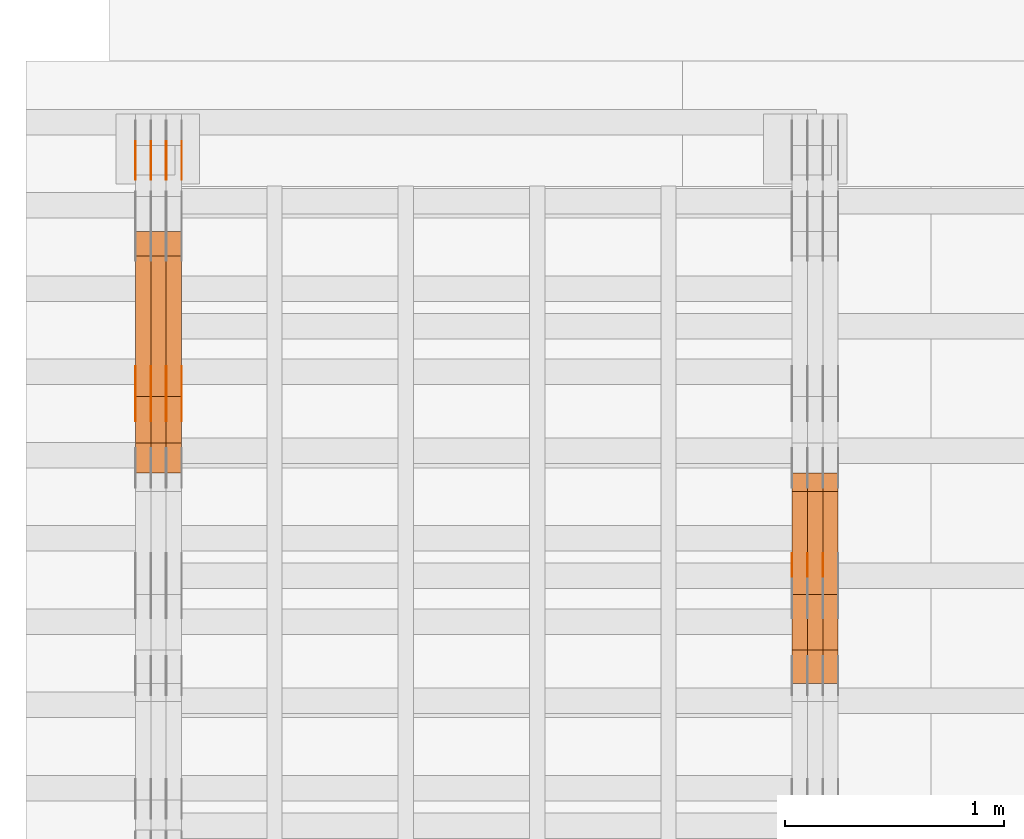
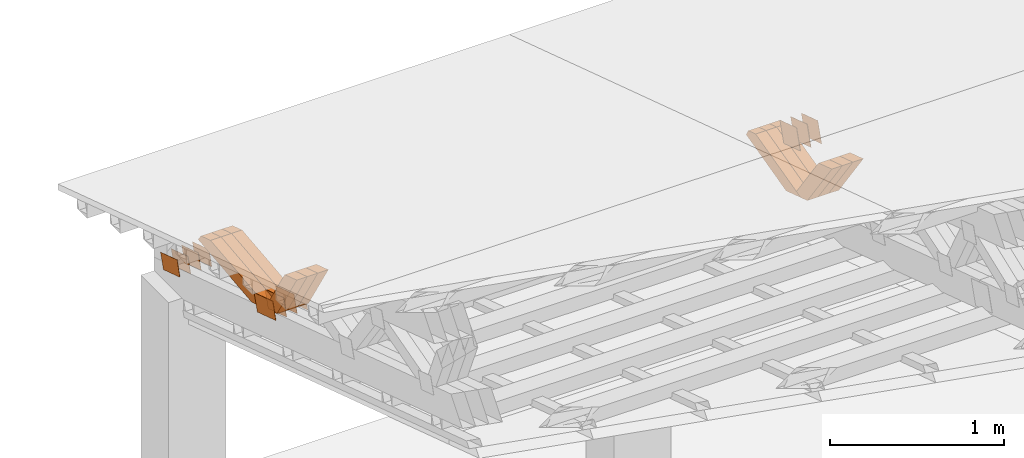
# One storey, part 184 of 385: 28 proxies.
"""IFC2X3 building model written with IfcOpenShell, lengths in millimetres."""

from ifc_helpers import new_model, entity, si_unit, converted_unit, derived_unit, direction, frame, origin, place, context, subcontext, project, spatial, polyline, outline, extrude, source, transform, mapped, material, type_object, type_shapes, element, save


model = new_model("IFC2X3")

# Units and contexts
model_context = context("Model", 3, precision=0.01, world=origin(), true_north=direction((6.12303176911189e-17, 1.0)))
body_context = subcontext(model_context, "Body", "Model", "MODEL_VIEW")
ifc_project = project(units=[si_unit("LENGTHUNIT", "METRE", prefix="MILLI"), si_unit("AREAUNIT", "SQUARE_METRE"), si_unit("VOLUMEUNIT", "CUBIC_METRE"), converted_unit("PLANEANGLEUNIT", "DEGREE", entity("IfcRatioMeasure", 0.0174532925199433), si_unit("PLANEANGLEUNIT", "RADIAN"), dimensions=[0, 0, 0, 0, 0, 0, 0]), si_unit("MASSUNIT", "GRAM", prefix="KILO"), derived_unit("MASSDENSITYUNIT", [(si_unit("MASSUNIT", "GRAM", prefix="KILO"), 1), (si_unit("LENGTHUNIT", "METRE"), -3)]), si_unit("TIMEUNIT", "SECOND"), si_unit("FREQUENCYUNIT", "HERTZ"), si_unit("THERMODYNAMICTEMPERATUREUNIT", "DEGREE_CELSIUS"), derived_unit("THERMALTRANSMITTANCEUNIT", [(si_unit("MASSUNIT", "GRAM", prefix="KILO"), 1), (si_unit("THERMODYNAMICTEMPERATUREUNIT", "KELVIN"), -1), (si_unit("TIMEUNIT", "SECOND"), -3)]), derived_unit("VOLUMETRICFLOWRATEUNIT", [(si_unit("LENGTHUNIT", "METRE"), 3), (si_unit("TIMEUNIT", "SECOND"), -1)]), si_unit("ELECTRICCURRENTUNIT", "AMPERE"), si_unit("ELECTRICVOLTAGEUNIT", "VOLT"), si_unit("POWERUNIT", "WATT"), si_unit("FORCEUNIT", "NEWTON", prefix="KILO"), si_unit("ILLUMINANCEUNIT", "LUX"), si_unit("LUMINOUSFLUXUNIT", "LUMEN"), si_unit("LUMINOUSINTENSITYUNIT", "CANDELA"), derived_unit("USERDEFINED", [(si_unit("MASSUNIT", "GRAM", prefix="KILO"), -1), (si_unit("LENGTHUNIT", "METRE"), -2), (si_unit("TIMEUNIT", "SECOND"), 3), (si_unit("LUMINOUSFLUXUNIT", "LUMEN"), 1)]), derived_unit("LINEARVELOCITYUNIT", [(si_unit("LENGTHUNIT", "METRE"), 1), (si_unit("TIMEUNIT", "SECOND"), -1)]), si_unit("PRESSUREUNIT", "PASCAL"), derived_unit("USERDEFINED", [(si_unit("LENGTHUNIT", "METRE"), -2), (si_unit("MASSUNIT", "GRAM", prefix="KILO"), 1), (si_unit("TIMEUNIT", "SECOND"), -2)])], contexts=[model_context])

# Site, building, storey
site_placement = place(None, origin())
site = spatial("IfcSite", under=ifc_project, at=site_placement, CompositionType="ELEMENT")
building_placement = place(site_placement, origin())
building = spatial("IfcBuilding", under=site, at=building_placement, CompositionType="ELEMENT")
storey_placement = place(building_placement, origin())
storey = spatial("IfcBuildingStorey", under=building, at=storey_placement, Name="Default", CompositionType="ELEMENT", Elevation=0.0)

# Proxies
ifc_material_1 = material(Name="IfcSurfaceStyle #54198")
building_element_proxy_type_1 = type_object("IfcBuildingElementProxyType", PredefinedType="NOTDEFINED", material=ifc_material_1)
shared_shape_1 = source(origin(), body_context, "Body", "SweptSolid", [
    extrude(outline(polyline([(-100.000009625089, -72.0000630699202), (100.000090167682, -72.0000630699202), (100.000009625089, 72.0000630699202), (-100.000090167682, 72.0000630699202), (-100.000009625089, -72.0000630699202)])), frame((100.000090167682, 72.0000630699202, 0.0), z_axis=(0.0, 0.0, 1.0), x_axis=(-1.0, 0.0, 0.0)), (0.0, 0.0, 1.0), 1.3),
])
type_shapes(building_element_proxy_type_1, [shared_shape_1])
proxy_1_placement = place(building_placement, frame((3316.29999999999, 24447.7695802369, 1088.58717039832), z_axis=(-1.0, 0.0, 0.0), x_axis=(0.0, -0.951056516295154, 0.309016994374948)))
element("IfcBuildingElementProxy", 1, at=proxy_1_placement, inside=storey, type_object=building_element_proxy_type_1, material=ifc_material_1, context=body_context, shape_type="MappedRepresentation", body=[
    mapped(shared_shape_1, transform((0.0, 0.0, 0.0), scale=1.0)),
])
ifc_material_2 = material(Name="IfcSurfaceStyle #54141")
building_element_proxy_type_2 = type_object("IfcBuildingElementProxyType", PredefinedType="NOTDEFINED", material=ifc_material_2)
shared_shape_2 = source(origin(), body_context, "Body", "SweptSolid", [
    extrude(outline(polyline([(-100.000009625089, -72.0000630699202), (100.000090167682, -72.0000630699202), (100.000009625089, 72.0000630699202), (-100.000090167682, 72.0000630699202), (-100.000009625089, -72.0000630699202)])), frame((100.000090167682, 72.0000630699202, 0.0), z_axis=(0.0, 0.0, 1.0), x_axis=(-1.0, 0.0, 0.0)), (0.0, 0.0, 1.0), 1.29999999999998),
])
type_shapes(building_element_proxy_type_2, [shared_shape_2])
proxy_2_placement = place(building_placement, frame((3245.0, 24447.7695802369, 1088.58717039832), z_axis=(-1.0, 0.0, 0.0), x_axis=(0.0, -0.951056516295154, 0.309016994374948)))
element("IfcBuildingElementProxy", 2, at=proxy_2_placement, inside=storey, type_object=building_element_proxy_type_2, material=ifc_material_2, context=body_context, shape_type="MappedRepresentation", body=[
    mapped(shared_shape_2, transform((0.0, 0.0, 0.0), scale=1.0)),
])
ifc_material_3 = material(Name="IfcSurfaceStyle #54084")
building_element_proxy_type_3 = type_object("IfcBuildingElementProxyType", PredefinedType="NOTDEFINED", material=ifc_material_3)
shared_shape_3 = source(origin(), body_context, "Body", "SweptSolid", [
    extrude(outline(polyline([(-100.000009625089, -72.0000630699202), (100.000090167682, -72.0000630699202), (100.000009625089, 72.0000630699202), (-100.000090167682, 72.0000630699202), (-100.000009625089, -72.0000630699202)])), frame((100.000090167682, 72.0000630699202, 0.0), z_axis=(0.0, 0.0, 1.0), x_axis=(-1.0, 0.0, 0.0)), (0.0, 0.0, 1.0), 1.29999999999998),
])
type_shapes(building_element_proxy_type_3, [shared_shape_3])
proxy_3_placement = place(building_placement, frame((3246.29999999999, 24447.7695802369, 1088.58717039832), z_axis=(-1.0, 0.0, 0.0), x_axis=(0.0, -0.951056516295154, 0.309016994374948)))
element("IfcBuildingElementProxy", 3, at=proxy_3_placement, inside=storey, type_object=building_element_proxy_type_3, material=ifc_material_3, context=body_context, shape_type="MappedRepresentation", body=[
    mapped(shared_shape_3, transform((0.0, 0.0, 0.0), scale=1.0)),
])
ifc_material_4 = material(Name="IfcSurfaceStyle #54027")
building_element_proxy_type_4 = type_object("IfcBuildingElementProxyType", PredefinedType="NOTDEFINED", material=ifc_material_4)
shared_shape_4 = source(origin(), body_context, "Body", "SweptSolid", [
    extrude(outline(polyline([(-100.000009625089, -72.0000630699202), (100.000090167682, -72.0000630699202), (100.000009625089, 72.0000630699202), (-100.000090167682, 72.0000630699202), (-100.000009625089, -72.0000630699202)])), frame((100.000090167682, 72.0000630699202, 0.0), z_axis=(0.0, 0.0, 1.0), x_axis=(-1.0, 0.0, 0.0)), (0.0, 0.0, 1.0), 1.29999999999999),
])
type_shapes(building_element_proxy_type_4, [shared_shape_4])
proxy_4_placement = place(building_placement, frame((3175.0, 24447.7695802369, 1088.58717039832), z_axis=(-1.0, 0.0, 0.0), x_axis=(0.0, -0.951056516295154, 0.309016994374948)))
element("IfcBuildingElementProxy", 4, at=proxy_4_placement, inside=storey, type_object=building_element_proxy_type_4, material=ifc_material_4, context=body_context, shape_type="MappedRepresentation", body=[
    mapped(shared_shape_4, transform((0.0, 0.0, 0.0), scale=1.0)),
])
ifc_material_5 = material(Name="IfcSurfaceStyle #45114")
building_element_proxy_type_5 = type_object("IfcBuildingElementProxyType", Name="T1-W24 45112", PredefinedType="NOTDEFINED", material=ifc_material_5)
shared_shape_5 = source(origin(), body_context, "Body", "SweptSolid", [
    extrude(outline(polyline([(-215.642157779899, -47.4998772343114), (220.829928576248, -47.4998772343114), (202.182343865616, 6.34871490324596e-05), (137.545638852774, 47.4998454907369), (-344.915753514738, 47.4998454907369), (-215.642157779899, -47.4998772343114)])), frame((220.830079609702, 47.500154567531, 0.0), z_axis=(0.0, 0.0, 1.0), x_axis=(-1.0, 0.0, 0.0)), (0.0, 0.0, 1.0), 70.0),
])
type_shapes(building_element_proxy_type_5, [shared_shape_5])
proxy_5_placement = place(building_placement, frame((3385.0, 24227.7045444998, 781.019082122604), z_axis=(-1.0, 0.0, 0.0), x_axis=(0.0, -0.583381854128324, 0.812198012970851)))
element("IfcBuildingElementProxy", 5, at=proxy_5_placement, inside=storey, type_object=building_element_proxy_type_5, material=ifc_material_5, Name="T1-W24", context=body_context, shape_type="MappedRepresentation", body=[
    mapped(shared_shape_5, transform((0.0, 0.0, 0.0), scale=1.0)),
])
ifc_material_6 = material(Name="IfcSurfaceStyle #45048")
building_element_proxy_type_6 = type_object("IfcBuildingElementProxyType", Name="T1-W24 45046", PredefinedType="NOTDEFINED", material=ifc_material_6)
shared_shape_6 = source(origin(), body_context, "Body", "SweptSolid", [
    extrude(outline(polyline([(-215.642157779899, -47.4998772343114), (220.829928576248, -47.4998772343114), (202.182343865616, 6.34871490324596e-05), (137.545638852774, 47.4998454907369), (-344.915753514738, 47.4998454907369), (-215.642157779899, -47.4998772343114)])), frame((220.830079609702, 47.500154567531, 0.0), z_axis=(0.0, 0.0, 1.0), x_axis=(-1.0, 0.0, 0.0)), (0.0, 0.0, 1.0), 70.0),
])
type_shapes(building_element_proxy_type_6, [shared_shape_6])
proxy_6_placement = place(building_placement, frame((3315.0, 24227.7045444998, 781.019082122604), z_axis=(-1.0, 0.0, 0.0), x_axis=(0.0, -0.583381854128324, 0.812198012970851)))
element("IfcBuildingElementProxy", 6, at=proxy_6_placement, inside=storey, type_object=building_element_proxy_type_6, material=ifc_material_6, Name="T1-W24", context=body_context, shape_type="MappedRepresentation", body=[
    mapped(shared_shape_6, transform((0.0, 0.0, 0.0), scale=1.0)),
])
ifc_material_7 = material(Name="IfcSurfaceStyle #44982")
building_element_proxy_type_7 = type_object("IfcBuildingElementProxyType", Name="T1-W24 44980", PredefinedType="NOTDEFINED", material=ifc_material_7)
shared_shape_7 = source(origin(), body_context, "Body", "SweptSolid", [
    extrude(outline(polyline([(-215.642157779899, -47.4998772343114), (220.829928576248, -47.4998772343114), (202.182343865616, 6.34871490324596e-05), (137.545638852774, 47.4998454907369), (-344.915753514738, 47.4998454907369), (-215.642157779899, -47.4998772343114)])), frame((220.830079609702, 47.500154567531, 0.0), z_axis=(0.0, 0.0, 1.0), x_axis=(-1.0, 0.0, 0.0)), (0.0, 0.0, 1.0), 70.0),
])
type_shapes(building_element_proxy_type_7, [shared_shape_7])
proxy_7_placement = place(building_placement, frame((3245.0, 24227.7045444998, 781.019082122604), z_axis=(-1.0, 0.0, 0.0), x_axis=(0.0, -0.583381854128324, 0.812198012970851)))
element("IfcBuildingElementProxy", 7, at=proxy_7_placement, inside=storey, type_object=building_element_proxy_type_7, material=ifc_material_7, Name="T1-W24", context=body_context, shape_type="MappedRepresentation", body=[
    mapped(shared_shape_7, transform((0.0, 0.0, 0.0), scale=1.0)),
])
ifc_material_8 = material(Name="IfcSurfaceStyle #44718")
building_element_proxy_type_8 = type_object("IfcBuildingElementProxyType", Name="T1-W13 44716", PredefinedType="NOTDEFINED", material=ifc_material_8)
shared_shape_8 = source(origin(), body_context, "Body", "SweptSolid", [
    extrude(outline(polyline([(-384.339592151497, -47.5000055308246), (150.996422207105, -47.5000055308247), (226.265349299398, -4.29484466835994e-05), (240.878612116891, 47.500027005048), (-233.800791471897, 47.500027005048), (-384.339592151497, -47.5000055308246)])), frame((240.878612116891, 47.500027005048, 0.0), z_axis=(0.0, 0.0, 1.0), x_axis=(-1.0, 0.0, 0.0)), (0.0, 0.0, 1.0), 70.0),
])
type_shapes(building_element_proxy_type_8, [shared_shape_8])
proxy_8_placement = place(building_placement, frame((3385.0, 24884.765625, 885.749145507813), z_axis=(-1.0, 0.0, 0.0), x_axis=(0.0, -0.969210894563555, -0.246232089418326)))
element("IfcBuildingElementProxy", 8, at=proxy_8_placement, inside=storey, type_object=building_element_proxy_type_8, material=ifc_material_8, Name="T1-W13", context=body_context, shape_type="MappedRepresentation", body=[
    mapped(shared_shape_8, transform((0.0, 0.0, 0.0), scale=1.0)),
])
ifc_material_9 = material(Name="IfcSurfaceStyle #44652")
building_element_proxy_type_9 = type_object("IfcBuildingElementProxyType", Name="T1-W13 44650", PredefinedType="NOTDEFINED", material=ifc_material_9)
shared_shape_9 = source(origin(), body_context, "Body", "SweptSolid", [
    extrude(outline(polyline([(-384.339592151497, -47.5000055308246), (150.996422207105, -47.5000055308247), (226.265349299398, -4.29484466835994e-05), (240.878612116891, 47.500027005048), (-233.800791471897, 47.500027005048), (-384.339592151497, -47.5000055308246)])), frame((240.878612116891, 47.500027005048, 0.0), z_axis=(0.0, 0.0, 1.0), x_axis=(-1.0, 0.0, 0.0)), (0.0, 0.0, 1.0), 70.0),
])
type_shapes(building_element_proxy_type_9, [shared_shape_9])
proxy_9_placement = place(building_placement, frame((3315.0, 24884.765625, 885.749145507813), z_axis=(-1.0, 0.0, 0.0), x_axis=(0.0, -0.969210894563555, -0.246232089418326)))
element("IfcBuildingElementProxy", 9, at=proxy_9_placement, inside=storey, type_object=building_element_proxy_type_9, material=ifc_material_9, Name="T1-W13", context=body_context, shape_type="MappedRepresentation", body=[
    mapped(shared_shape_9, transform((0.0, 0.0, 0.0), scale=1.0)),
])
ifc_material_10 = material(Name="IfcSurfaceStyle #44586")
building_element_proxy_type_10 = type_object("IfcBuildingElementProxyType", Name="T1-W13 44584", PredefinedType="NOTDEFINED", material=ifc_material_10)
shared_shape_10 = source(origin(), body_context, "Body", "SweptSolid", [
    extrude(outline(polyline([(-384.339592151497, -47.5000055308246), (150.996422207105, -47.5000055308247), (226.265349299398, -4.29484466835994e-05), (240.878612116891, 47.500027005048), (-233.800791471897, 47.500027005048), (-384.339592151497, -47.5000055308246)])), frame((240.878612116891, 47.500027005048, 0.0), z_axis=(0.0, 0.0, 1.0), x_axis=(-1.0, 0.0, 0.0)), (0.0, 0.0, 1.0), 70.0),
])
type_shapes(building_element_proxy_type_10, [shared_shape_10])
proxy_10_placement = place(building_placement, frame((3245.0, 24884.765625, 885.749145507813), z_axis=(-1.0, 0.0, 0.0), x_axis=(0.0, -0.969210894563555, -0.246232089418326)))
element("IfcBuildingElementProxy", 10, at=proxy_10_placement, inside=storey, type_object=building_element_proxy_type_10, material=ifc_material_10, Name="T1-W13", context=body_context, shape_type="MappedRepresentation", body=[
    mapped(shared_shape_10, transform((0.0, 0.0, 0.0), scale=1.0)),
])
ifc_material_11 = material(Name="IfcSurfaceStyle #33902")
building_element_proxy_type_11 = type_object("IfcBuildingElementProxyType", PredefinedType="NOTDEFINED", material=ifc_material_11)
shared_shape_11 = source(origin(), body_context, "Body", "SweptSolid", [
    extrude(outline(polyline([(-100.000024997547, -54.0000105875654), (100.000088940899, -54.0000105875654), (99.9999100805868, 54.0000105875654), (-99.9999740239394, 54.0000105875654), (-100.000024997547, -54.0000105875654)])), frame((100.000088940899, 54.0000474633838, 0.0), z_axis=(0.0, 0.0, 1.0), x_axis=(-1.0, 0.0, 0.0)), (0.0, 0.0, 1.0), 1.3),
])
type_shapes(building_element_proxy_type_11, [shared_shape_11])
proxy_11_placement = place(building_placement, frame((386.299999999986, 26390.6212638563, 73.3227520411355), z_axis=(-1.0, 0.0, 0.0), x_axis=(0.0, -0.951056516295124, 0.309016994375039)))
element("IfcBuildingElementProxy", 11, at=proxy_11_placement, inside=storey, type_object=building_element_proxy_type_11, material=ifc_material_11, context=body_context, shape_type="MappedRepresentation", body=[
    mapped(shared_shape_11, transform((0.0, 0.0, 0.0), scale=1.0)),
])
ifc_material_12 = material(Name="IfcSurfaceStyle #33845")
building_element_proxy_type_12 = type_object("IfcBuildingElementProxyType", PredefinedType="NOTDEFINED", material=ifc_material_12)
shared_shape_12 = source(origin(), body_context, "Body", "SweptSolid", [
    extrude(outline(polyline([(-100.000024997547, -54.0000105875654), (100.000088940899, -54.0000105875654), (99.9999100805868, 54.0000105875654), (-99.9999740239394, 54.0000105875654), (-100.000024997547, -54.0000105875654)])), frame((100.000088940899, 54.0000474633838, 0.0), z_axis=(0.0, 0.0, 1.0), x_axis=(-1.0, 0.0, 0.0)), (0.0, 0.0, 1.0), 1.3),
])
type_shapes(building_element_proxy_type_12, [shared_shape_12])
proxy_12_placement = place(building_placement, frame((315.0, 26390.6212638563, 73.3227520411355), z_axis=(-1.0, 0.0, 0.0), x_axis=(0.0, -0.951056516295124, 0.309016994375039)))
element("IfcBuildingElementProxy", 12, at=proxy_12_placement, inside=storey, type_object=building_element_proxy_type_12, material=ifc_material_12, context=body_context, shape_type="MappedRepresentation", body=[
    mapped(shared_shape_12, transform((0.0, 0.0, 0.0), scale=1.0)),
])
ifc_material_13 = material(Name="IfcSurfaceStyle #33788")
building_element_proxy_type_13 = type_object("IfcBuildingElementProxyType", PredefinedType="NOTDEFINED", material=ifc_material_13)
shared_shape_13 = source(origin(), body_context, "Body", "SweptSolid", [
    extrude(outline(polyline([(-100.000024997547, -54.0000105875654), (100.000088940899, -54.0000105875654), (99.9999100805868, 54.0000105875654), (-99.9999740239394, 54.0000105875654), (-100.000024997547, -54.0000105875654)])), frame((100.000088940899, 54.0000474633838, 0.0), z_axis=(0.0, 0.0, 1.0), x_axis=(-1.0, 0.0, 0.0)), (0.0, 0.0, 1.0), 1.3),
])
type_shapes(building_element_proxy_type_13, [shared_shape_13])
proxy_13_placement = place(building_placement, frame((316.299999999986, 26390.6212638563, 73.3227520411355), z_axis=(-1.0, 0.0, 0.0), x_axis=(0.0, -0.951056516295124, 0.309016994375039)))
element("IfcBuildingElementProxy", 13, at=proxy_13_placement, inside=storey, type_object=building_element_proxy_type_13, material=ifc_material_13, context=body_context, shape_type="MappedRepresentation", body=[
    mapped(shared_shape_13, transform((0.0, 0.0, 0.0), scale=1.0)),
])
ifc_material_14 = material(Name="IfcSurfaceStyle #33731")
building_element_proxy_type_14 = type_object("IfcBuildingElementProxyType", PredefinedType="NOTDEFINED", material=ifc_material_14)
shared_shape_14 = source(origin(), body_context, "Body", "SweptSolid", [
    extrude(outline(polyline([(-100.000024997547, -54.0000105875654), (100.000088940899, -54.0000105875654), (99.9999100805868, 54.0000105875654), (-99.9999740239394, 54.0000105875654), (-100.000024997547, -54.0000105875654)])), frame((100.000088940899, 54.0000474633838, 0.0), z_axis=(0.0, 0.0, 1.0), x_axis=(-1.0, 0.0, 0.0)), (0.0, 0.0, 1.0), 1.29999999999998),
])
type_shapes(building_element_proxy_type_14, [shared_shape_14])
proxy_14_placement = place(building_placement, frame((245.0, 26390.6212638563, 73.3227520411355), z_axis=(-1.0, 0.0, 0.0), x_axis=(0.0, -0.951056516295124, 0.309016994375039)))
element("IfcBuildingElementProxy", 14, at=proxy_14_placement, inside=storey, type_object=building_element_proxy_type_14, material=ifc_material_14, context=body_context, shape_type="MappedRepresentation", body=[
    mapped(shared_shape_14, transform((0.0, 0.0, 0.0), scale=1.0)),
])
ifc_material_15 = material(Name="IfcSurfaceStyle #33674")
building_element_proxy_type_15 = type_object("IfcBuildingElementProxyType", PredefinedType="NOTDEFINED", material=ifc_material_15)
shared_shape_15 = source(origin(), body_context, "Body", "SweptSolid", [
    extrude(outline(polyline([(-100.000024997547, -54.0000105875654), (100.000088940899, -54.0000105875654), (99.9999100805868, 54.0000105875654), (-99.9999740239394, 54.0000105875654), (-100.000024997547, -54.0000105875654)])), frame((100.000088940899, 54.0000474633838, 0.0), z_axis=(0.0, 0.0, 1.0), x_axis=(-1.0, 0.0, 0.0)), (0.0, 0.0, 1.0), 1.29999999999998),
])
type_shapes(building_element_proxy_type_15, [shared_shape_15])
proxy_15_placement = place(building_placement, frame((246.299999999986, 26390.6212638563, 73.3227520411355), z_axis=(-1.0, 0.0, 0.0), x_axis=(0.0, -0.951056516295124, 0.309016994375039)))
element("IfcBuildingElementProxy", 15, at=proxy_15_placement, inside=storey, type_object=building_element_proxy_type_15, material=ifc_material_15, context=body_context, shape_type="MappedRepresentation", body=[
    mapped(shared_shape_15, transform((0.0, 0.0, 0.0), scale=1.0)),
])
ifc_material_16 = material(Name="IfcSurfaceStyle #33617")
building_element_proxy_type_16 = type_object("IfcBuildingElementProxyType", PredefinedType="NOTDEFINED", material=ifc_material_16)
shared_shape_16 = source(origin(), body_context, "Body", "SweptSolid", [
    extrude(outline(polyline([(-100.000024997547, -54.0000105875654), (100.000088940899, -54.0000105875654), (99.9999100805868, 54.0000105875654), (-99.9999740239394, 54.0000105875654), (-100.000024997547, -54.0000105875654)])), frame((100.000088940899, 54.0000474633838, 0.0), z_axis=(0.0, 0.0, 1.0), x_axis=(-1.0, 0.0, 0.0)), (0.0, 0.0, 1.0), 1.29999999999999),
])
type_shapes(building_element_proxy_type_16, [shared_shape_16])
proxy_16_placement = place(building_placement, frame((175.0, 26390.6212638563, 73.3227520411355), z_axis=(-1.0, 0.0, 0.0), x_axis=(0.0, -0.951056516295124, 0.309016994375039)))
element("IfcBuildingElementProxy", 16, at=proxy_16_placement, inside=storey, type_object=building_element_proxy_type_16, material=ifc_material_16, context=body_context, shape_type="MappedRepresentation", body=[
    mapped(shared_shape_16, transform((0.0, 0.0, 0.0), scale=1.0)),
])
ifc_material_17 = material(Name="IfcSurfaceStyle #21932")
building_element_proxy_type_17 = type_object("IfcBuildingElementProxyType", PredefinedType="NOTDEFINED", material=ifc_material_17)
shared_shape_17 = source(origin(), body_context, "Body", "SweptSolid", [
    extrude(outline(polyline([(-112.50003853564, -60.0000121429077), (112.50002982902, -60.0000121429077), (112.500043250865, 60.0000121429077), (-112.500034544245, 60.0000121429077), (-112.50003853564, -60.0000121429077)])), frame((112.500056021398, 60.0000121429077, 0.0), z_axis=(0.0, 0.0, 1.0), x_axis=(-1.0, 0.0, 0.0)), (0.0, 0.0, 1.0), 1.3),
])
type_shapes(building_element_proxy_type_17, [shared_shape_17])
proxy_17_placement = place(building_placement, frame((386.299999999986, 25310.2182710494, 430.675738123044), z_axis=(-1.0, 0.0, 0.0), x_axis=(0.0, -0.951056516295124, 0.309016994375039)))
element("IfcBuildingElementProxy", 17, at=proxy_17_placement, inside=storey, type_object=building_element_proxy_type_17, material=ifc_material_17, context=body_context, shape_type="MappedRepresentation", body=[
    mapped(shared_shape_17, transform((0.0, 0.0, 0.0), scale=1.0)),
])
ifc_material_18 = material(Name="IfcSurfaceStyle #21875")
building_element_proxy_type_18 = type_object("IfcBuildingElementProxyType", PredefinedType="NOTDEFINED", material=ifc_material_18)
shared_shape_18 = source(origin(), body_context, "Body", "SweptSolid", [
    extrude(outline(polyline([(-112.50003853564, -60.0000121429077), (112.50002982902, -60.0000121429077), (112.500043250865, 60.0000121429077), (-112.500034544245, 60.0000121429077), (-112.50003853564, -60.0000121429077)])), frame((112.500056021398, 60.0000121429077, 0.0), z_axis=(0.0, 0.0, 1.0), x_axis=(-1.0, 0.0, 0.0)), (0.0, 0.0, 1.0), 1.3),
])
type_shapes(building_element_proxy_type_18, [shared_shape_18])
proxy_18_placement = place(building_placement, frame((315.0, 25310.2182710494, 430.675738123044), z_axis=(-1.0, 0.0, 0.0), x_axis=(0.0, -0.951056516295124, 0.309016994375039)))
element("IfcBuildingElementProxy", 18, at=proxy_18_placement, inside=storey, type_object=building_element_proxy_type_18, material=ifc_material_18, context=body_context, shape_type="MappedRepresentation", body=[
    mapped(shared_shape_18, transform((0.0, 0.0, 0.0), scale=1.0)),
])
ifc_material_19 = material(Name="IfcSurfaceStyle #21818")
building_element_proxy_type_19 = type_object("IfcBuildingElementProxyType", PredefinedType="NOTDEFINED", material=ifc_material_19)
shared_shape_19 = source(origin(), body_context, "Body", "SweptSolid", [
    extrude(outline(polyline([(-112.50003853564, -60.0000121429077), (112.50002982902, -60.0000121429077), (112.500043250865, 60.0000121429077), (-112.500034544245, 60.0000121429077), (-112.50003853564, -60.0000121429077)])), frame((112.500056021398, 60.0000121429077, 0.0), z_axis=(0.0, 0.0, 1.0), x_axis=(-1.0, 0.0, 0.0)), (0.0, 0.0, 1.0), 1.3),
])
type_shapes(building_element_proxy_type_19, [shared_shape_19])
proxy_19_placement = place(building_placement, frame((316.299999999986, 25310.2182710494, 430.675738123044), z_axis=(-1.0, 0.0, 0.0), x_axis=(0.0, -0.951056516295124, 0.309016994375039)))
element("IfcBuildingElementProxy", 19, at=proxy_19_placement, inside=storey, type_object=building_element_proxy_type_19, material=ifc_material_19, context=body_context, shape_type="MappedRepresentation", body=[
    mapped(shared_shape_19, transform((0.0, 0.0, 0.0), scale=1.0)),
])
ifc_material_20 = material(Name="IfcSurfaceStyle #21761")
building_element_proxy_type_20 = type_object("IfcBuildingElementProxyType", PredefinedType="NOTDEFINED", material=ifc_material_20)
shared_shape_20 = source(origin(), body_context, "Body", "SweptSolid", [
    extrude(outline(polyline([(-112.50003853564, -60.0000121429077), (112.50002982902, -60.0000121429077), (112.500043250865, 60.0000121429077), (-112.500034544245, 60.0000121429077), (-112.50003853564, -60.0000121429077)])), frame((112.500056021398, 60.0000121429077, 0.0), z_axis=(0.0, 0.0, 1.0), x_axis=(-1.0, 0.0, 0.0)), (0.0, 0.0, 1.0), 1.29999999999998),
])
type_shapes(building_element_proxy_type_20, [shared_shape_20])
proxy_20_placement = place(building_placement, frame((245.0, 25310.2182710494, 430.675738123044), z_axis=(-1.0, 0.0, 0.0), x_axis=(0.0, -0.951056516295124, 0.309016994375039)))
element("IfcBuildingElementProxy", 20, at=proxy_20_placement, inside=storey, type_object=building_element_proxy_type_20, material=ifc_material_20, context=body_context, shape_type="MappedRepresentation", body=[
    mapped(shared_shape_20, transform((0.0, 0.0, 0.0), scale=1.0)),
])
ifc_material_21 = material(Name="IfcSurfaceStyle #21704")
building_element_proxy_type_21 = type_object("IfcBuildingElementProxyType", PredefinedType="NOTDEFINED", material=ifc_material_21)
shared_shape_21 = source(origin(), body_context, "Body", "SweptSolid", [
    extrude(outline(polyline([(-112.50003853564, -60.0000121429077), (112.50002982902, -60.0000121429077), (112.500043250865, 60.0000121429077), (-112.500034544245, 60.0000121429077), (-112.50003853564, -60.0000121429077)])), frame((112.500056021398, 60.0000121429077, 0.0), z_axis=(0.0, 0.0, 1.0), x_axis=(-1.0, 0.0, 0.0)), (0.0, 0.0, 1.0), 1.29999999999998),
])
type_shapes(building_element_proxy_type_21, [shared_shape_21])
proxy_21_placement = place(building_placement, frame((246.299999999986, 25310.2182710494, 430.675738123044), z_axis=(-1.0, 0.0, 0.0), x_axis=(0.0, -0.951056516295124, 0.309016994375039)))
element("IfcBuildingElementProxy", 21, at=proxy_21_placement, inside=storey, type_object=building_element_proxy_type_21, material=ifc_material_21, context=body_context, shape_type="MappedRepresentation", body=[
    mapped(shared_shape_21, transform((0.0, 0.0, 0.0), scale=1.0)),
])
ifc_material_22 = material(Name="IfcSurfaceStyle #21647")
building_element_proxy_type_22 = type_object("IfcBuildingElementProxyType", PredefinedType="NOTDEFINED", material=ifc_material_22)
shared_shape_22 = source(origin(), body_context, "Body", "SweptSolid", [
    extrude(outline(polyline([(-112.50003853564, -60.0000121429077), (112.50002982902, -60.0000121429077), (112.500043250865, 60.0000121429077), (-112.500034544245, 60.0000121429077), (-112.50003853564, -60.0000121429077)])), frame((112.500056021398, 60.0000121429077, 0.0), z_axis=(0.0, 0.0, 1.0), x_axis=(-1.0, 0.0, 0.0)), (0.0, 0.0, 1.0), 1.29999999999999),
])
type_shapes(building_element_proxy_type_22, [shared_shape_22])
proxy_22_placement = place(building_placement, frame((175.0, 25310.2182710494, 430.675738123044), z_axis=(-1.0, 0.0, 0.0), x_axis=(0.0, -0.951056516295124, 0.309016994375039)))
element("IfcBuildingElementProxy", 22, at=proxy_22_placement, inside=storey, type_object=building_element_proxy_type_22, material=ifc_material_22, context=body_context, shape_type="MappedRepresentation", body=[
    mapped(shared_shape_22, transform((0.0, 0.0, 0.0), scale=1.0)),
])
ifc_material_23 = material(Name="IfcSurfaceStyle #9890")
building_element_proxy_type_23 = type_object("IfcBuildingElementProxyType", Name="T1-W31 9888", PredefinedType="NOTDEFINED", material=ifc_material_23)
shared_shape_23 = source(origin(), body_context, "Body", "SweptSolid", [
    extrude(outline(polyline([(-201.245318299844, -47.5000121670808), (204.413774229459, -47.5000121670808), (182.034306640891, 5.35692244583164e-05), (126.70380769348, 47.4999853824686), (-311.906570263987, 47.4999853824686), (-201.245318299844, -47.5000121670808)])), frame((204.413774229459, 47.5002684334588, 0.0), z_axis=(0.0, 0.0, 1.0), x_axis=(-1.0, 0.0, 0.0)), (0.0, 0.0, 1.0), 70.0),
])
type_shapes(building_element_proxy_type_23, [shared_shape_23])
proxy_23_placement = place(building_placement, frame((385.0, 25127.5652647985, 487.27008059185), z_axis=(-1.0, 0.0, 0.0), x_axis=(0.0, -0.520333970303023, 0.853962855953755)))
element("IfcBuildingElementProxy", 23, at=proxy_23_placement, inside=storey, type_object=building_element_proxy_type_23, material=ifc_material_23, Name="T1-W31", context=body_context, shape_type="MappedRepresentation", body=[
    mapped(shared_shape_23, transform((0.0, 0.0, 0.0), scale=1.0)),
])
ifc_material_24 = material(Name="IfcSurfaceStyle #9824")
building_element_proxy_type_24 = type_object("IfcBuildingElementProxyType", Name="T1-W31 9822", PredefinedType="NOTDEFINED", material=ifc_material_24)
shared_shape_24 = source(origin(), body_context, "Body", "SweptSolid", [
    extrude(outline(polyline([(-201.245318299844, -47.5000121670808), (204.413774229459, -47.5000121670808), (182.034306640891, 5.35692244583164e-05), (126.70380769348, 47.4999853824686), (-311.906570263987, 47.4999853824686), (-201.245318299844, -47.5000121670808)])), frame((204.413774229459, 47.5002684334588, 0.0), z_axis=(0.0, 0.0, 1.0), x_axis=(-1.0, 0.0, 0.0)), (0.0, 0.0, 1.0), 70.0),
])
type_shapes(building_element_proxy_type_24, [shared_shape_24])
proxy_24_placement = place(building_placement, frame((315.0, 25127.5652647985, 487.27008059185), z_axis=(-1.0, 0.0, 0.0), x_axis=(0.0, -0.520333970303023, 0.853962855953755)))
element("IfcBuildingElementProxy", 24, at=proxy_24_placement, inside=storey, type_object=building_element_proxy_type_24, material=ifc_material_24, Name="T1-W31", context=body_context, shape_type="MappedRepresentation", body=[
    mapped(shared_shape_24, transform((0.0, 0.0, 0.0), scale=1.0)),
])
ifc_material_25 = material(Name="IfcSurfaceStyle #9758")
building_element_proxy_type_25 = type_object("IfcBuildingElementProxyType", Name="T1-W31 9756", PredefinedType="NOTDEFINED", material=ifc_material_25)
shared_shape_25 = source(origin(), body_context, "Body", "SweptSolid", [
    extrude(outline(polyline([(-201.245318299844, -47.5000121670808), (204.413774229459, -47.5000121670808), (182.034306640891, 5.35692244583164e-05), (126.70380769348, 47.4999853824686), (-311.906570263987, 47.4999853824686), (-201.245318299844, -47.5000121670808)])), frame((204.413774229459, 47.5002684334588, 0.0), z_axis=(0.0, 0.0, 1.0), x_axis=(-1.0, 0.0, 0.0)), (0.0, 0.0, 1.0), 70.0),
])
type_shapes(building_element_proxy_type_25, [shared_shape_25])
proxy_25_placement = place(building_placement, frame((245.0, 25127.5652647985, 487.27008059185), z_axis=(-1.0, 0.0, 0.0), x_axis=(0.0, -0.520333970303023, 0.853962855953755)))
element("IfcBuildingElementProxy", 25, at=proxy_25_placement, inside=storey, type_object=building_element_proxy_type_25, material=ifc_material_25, Name="T1-W31", context=body_context, shape_type="MappedRepresentation", body=[
    mapped(shared_shape_25, transform((0.0, 0.0, 0.0), scale=1.0)),
])
ifc_material_26 = material(Name="IfcSurfaceStyle #9494")
building_element_proxy_type_26 = type_object("IfcBuildingElementProxyType", Name="T1-W4 9492", PredefinedType="NOTDEFINED", material=ifc_material_26)
shared_shape_26 = source(origin(), body_context, "Body", "SweptSolid", [
    extrude(outline(polyline([(-510.077325435179, -47.4999981284922), (188.854793418912, -47.4999981284922), (294.906688207675, 1.67015383116809e-05), (324.289382923648, 47.499989777723), (-297.973539115057, 47.4999897777231), (-510.077325435179, -47.4999981284922)])), frame((324.289382923648, 47.5000278316275, 0.0), z_axis=(0.0, 0.0, 1.0), x_axis=(-1.0, 0.0, 0.0)), (0.0, 0.0, 1.0), 70.0),
])
type_shapes(building_element_proxy_type_26, [shared_shape_26])
proxy_26_placement = place(building_placement, frame((385.0, 25996.2241251556, 525.69905884318), z_axis=(-1.0, 0.0, 0.0), x_axis=(0.0, -0.994287125203057, -0.106738524701444)))
element("IfcBuildingElementProxy", 26, at=proxy_26_placement, inside=storey, type_object=building_element_proxy_type_26, material=ifc_material_26, Name="T1-W4", context=body_context, shape_type="MappedRepresentation", body=[
    mapped(shared_shape_26, transform((0.0, 0.0, 0.0), scale=1.0)),
])
ifc_material_27 = material(Name="IfcSurfaceStyle #9428")
building_element_proxy_type_27 = type_object("IfcBuildingElementProxyType", Name="T1-W4 9426", PredefinedType="NOTDEFINED", material=ifc_material_27)
shared_shape_27 = source(origin(), body_context, "Body", "SweptSolid", [
    extrude(outline(polyline([(-510.077325435179, -47.4999981284922), (188.854793418912, -47.4999981284922), (294.906688207675, 1.67015383116809e-05), (324.289382923648, 47.499989777723), (-297.973539115057, 47.4999897777231), (-510.077325435179, -47.4999981284922)])), frame((324.289382923648, 47.5000278316275, 0.0), z_axis=(0.0, 0.0, 1.0), x_axis=(-1.0, 0.0, 0.0)), (0.0, 0.0, 1.0), 70.0),
])
type_shapes(building_element_proxy_type_27, [shared_shape_27])
proxy_27_placement = place(building_placement, frame((315.0, 25996.2241251556, 525.69905884318), z_axis=(-1.0, 0.0, 0.0), x_axis=(0.0, -0.994287125203057, -0.106738524701444)))
element("IfcBuildingElementProxy", 27, at=proxy_27_placement, inside=storey, type_object=building_element_proxy_type_27, material=ifc_material_27, Name="T1-W4", context=body_context, shape_type="MappedRepresentation", body=[
    mapped(shared_shape_27, transform((0.0, 0.0, 0.0), scale=1.0)),
])
ifc_material_28 = material(Name="IfcSurfaceStyle #9362")
building_element_proxy_type_28 = type_object("IfcBuildingElementProxyType", Name="T1-W4 9360", PredefinedType="NOTDEFINED", material=ifc_material_28)
shared_shape_28 = source(origin(), body_context, "Body", "SweptSolid", [
    extrude(outline(polyline([(-510.077325435179, -47.4999981284922), (188.854793418912, -47.4999981284922), (294.906688207675, 1.67015383116809e-05), (324.289382923648, 47.499989777723), (-297.973539115057, 47.4999897777231), (-510.077325435179, -47.4999981284922)])), frame((324.289382923648, 47.5000278316275, 0.0), z_axis=(0.0, 0.0, 1.0), x_axis=(-1.0, 0.0, 0.0)), (0.0, 0.0, 1.0), 70.0),
])
type_shapes(building_element_proxy_type_28, [shared_shape_28])
proxy_28_placement = place(building_placement, frame((245.0, 25996.2241251556, 525.69905884318), z_axis=(-1.0, 0.0, 0.0), x_axis=(0.0, -0.994287125203057, -0.106738524701444)))
element("IfcBuildingElementProxy", 28, at=proxy_28_placement, inside=storey, type_object=building_element_proxy_type_28, material=ifc_material_28, Name="T1-W4", context=body_context, shape_type="MappedRepresentation", body=[
    mapped(shared_shape_28, transform((0.0, 0.0, 0.0), scale=1.0)),
])

save(model, "model.ifc")
